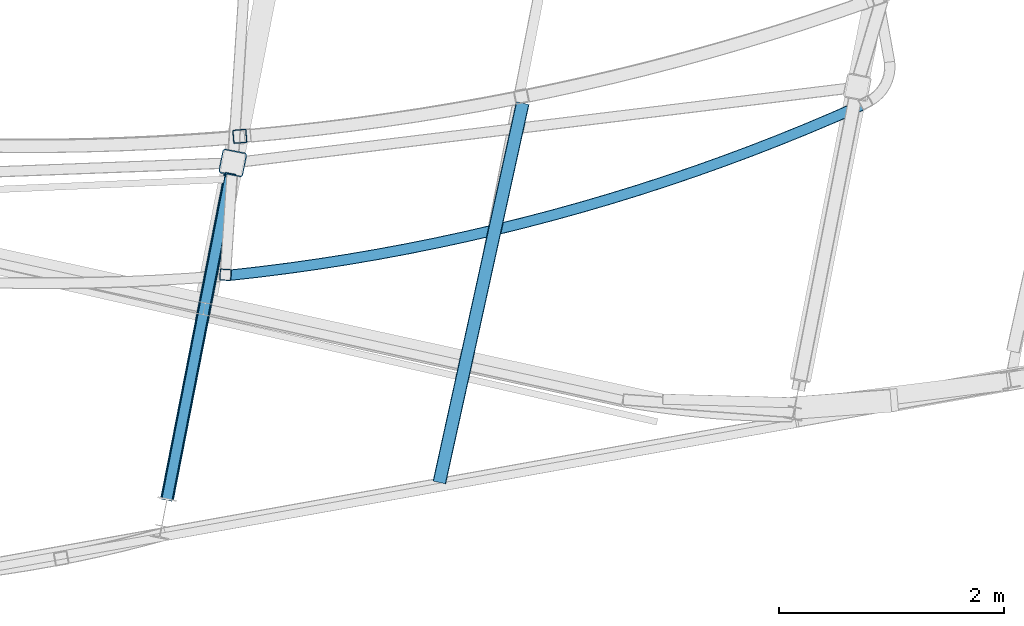
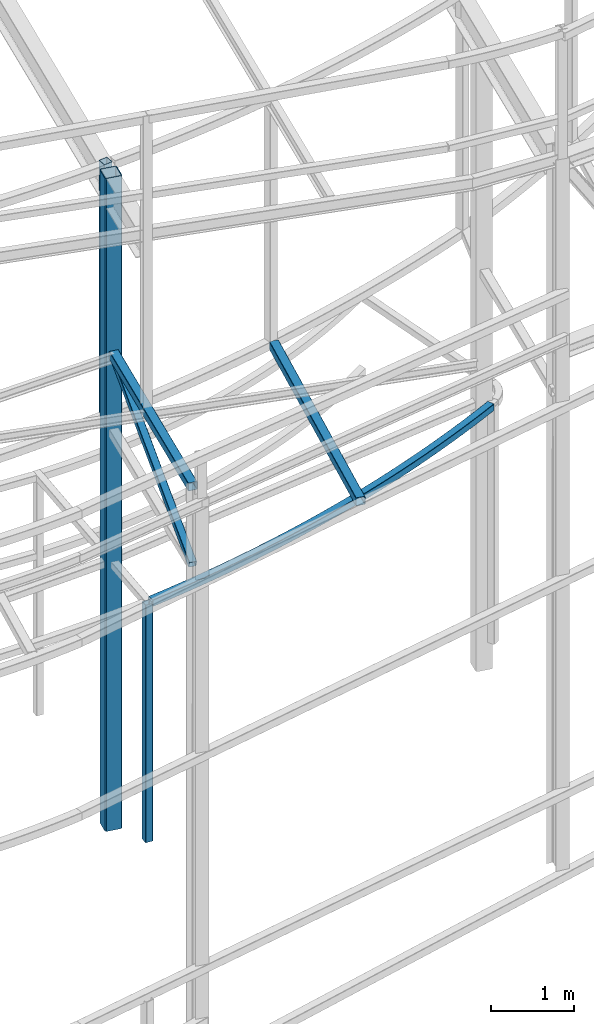
# One storey, part 52 of 215: 6 beams, 1 member, 7 elements without a shape of their own.
"""IFC2X3 building model written with IfcOpenShell, lengths in millimetres."""

from ifc_helpers import new_model, entity, si_unit, frame, origin_with_axes, origin_2d_with_axis, place, context, subcontext, project, spatial, hollow_rectangle, extrude, material, type_object, element, aggregate, save


model = new_model("IFC2X3")

# Units and contexts
model_context = context("Model", 3, precision=1e-05, world=origin_with_axes())
body_context = subcontext(model_context, "Body", "Model", "MODEL_VIEW")
ifc_project = project(units=[si_unit("LENGTHUNIT", "METRE", prefix="MILLI"), si_unit("AREAUNIT", "SQUARE_METRE"), si_unit("VOLUMEUNIT", "CUBIC_METRE"), si_unit("MASSUNIT", "GRAM", prefix="KILO"), si_unit("TIMEUNIT", "SECOND"), si_unit("PLANEANGLEUNIT", "RADIAN"), si_unit("SOLIDANGLEUNIT", "STERADIAN"), si_unit("THERMODYNAMICTEMPERATUREUNIT", "DEGREE_CELSIUS"), si_unit("LUMINOUSINTENSITYUNIT", "LUMEN")], contexts=[model_context])

# Site, building, storey
site_placement = place(None, origin_with_axes())
site = spatial("IfcSite", under=ifc_project, at=site_placement, CompositionType="ELEMENT")
building_placement = place(site_placement, origin_with_axes())
building = spatial("IfcBuilding", under=site, at=building_placement, Name="Undefined", CompositionType="ELEMENT")
storey_placement = place(building_placement, origin_with_axes())
storey = spatial("IfcBuildingStorey", under=building, at=storey_placement, Name="Undefined", CompositionType="ELEMENT", Elevation=0.0)

# Assembly, beam
assembly_1_placement = place(storey_placement, origin_with_axes())
assembly_1 = element("IfcElementAssembly", 1, at=assembly_1_placement, inside=storey, Name="Steel Assembly", AssemblyPlace="NOTDEFINED", PredefinedType="RIGID_FRAME")
ifc_material = material(Name="STEEL/S275JR")
beam_type_1 = type_object("IfcBeamType", PredefinedType="NOTDEFINED")
beam_1_placement = place(assembly_1_placement, frame((79141.1914420847, 2960.93035332073, 6760.00000147689), z_axis=(-0.259963625925388, 0.96561840972287, 0.0), x_axis=(0.96561840972287, 0.259963625925391, 0.0)))
beam_1 = element("IfcBeam", 2, at=beam_1_placement, type_object=beam_type_1, material=ifc_material, Name="POUTRE", context=body_context, shape_type="SweptSolid", body=[
    entity("IfcRevolvedAreaSolid", entity("IfcRectangleHollowProfileDef", "AREA", None, entity("IfcAxis2Placement2D", entity("IfcCartesianPoint", [0.0, 0.0]), entity("IfcDirection", [1.0, 0.0])), 100.0, 100.0, 4.0, 4.0, 8.0), entity("IfcAxis2Placement3D", entity("IfcCartesianPoint", [5816.07348706532, 0.0, -3.22856934912592e-13]), entity("IfcDirection", [-0.987500292888729, 0.0, -0.157617167671147]), entity("IfcDirection", [-6.93889390390723e-18, -1.0, -3.46944695195361e-18])), entity("IfcAxis1Placement", entity("IfcCartesianPoint", [0.0, 18450.0, 0.0]), entity("IfcDirection", [-1.0, 0.0, 0.0])), 0.316554383414073),
])
aggregate(assembly_1, [beam_1])

assembly_2_placement = place(storey_placement, origin_with_axes())
assembly_2 = element("IfcElementAssembly", 3, at=assembly_2_placement, inside=storey, Name="Steel Assembly", AssemblyPlace="NOTDEFINED", PredefinedType="RIGID_FRAME")
beam_2_placement = place(assembly_2_placement, frame((79099.7624666083, 2964.33186140651, 6760.00000147429), z_axis=(-0.99789749179923, 0.0648120039869599, 0.0), x_axis=(0.0, 0.0, -1.0)))
beam_2 = element("IfcBeam", 4, at=beam_2_placement, type_object=beam_type_1, material=ifc_material, Name="MONTANT", context=body_context, shape_type="SweptSolid", body=[
    extrude(hollow_rectangle(XDim=100.0, YDim=100.0, WallThickness=4.0, InnerFilletRadius=4.0, OuterFilletRadius=8.0, at=origin_2d_with_axis()), frame((3499.99999998675, 0.0, 0.0), z_axis=(-1.0, 0.0, 0.0), x_axis=(-6.93889390390723e-18, -1.0, -3.46944695195361e-18)), (0.0, 0.0, 1.0), 3500.0),
])
aggregate(assembly_2, [beam_2])

assembly_3_placement = place(storey_placement, origin_with_axes())
assembly_3 = element("IfcElementAssembly", 5, at=assembly_3_placement, inside=storey, Name="Steel Assembly", AssemblyPlace="NOTDEFINED", PredefinedType="RIGID_FRAME")
beam_type_2 = type_object("IfcBeamType", PredefinedType="NOTDEFINED")
beam_3_placement = place(assembly_3_placement, frame((81745.0894080744, 4492.63761610524, 8706.00014747974), z_axis=(0.976698644234717, -0.214615373051574, -1.00000033877607e-09), x_axis=(-0.214615373051576, -0.976698644234716, 0.0)))
beam_3 = element("IfcBeam", 6, at=beam_3_placement, type_object=beam_type_2, material=ifc_material, Name="LISSE", context=body_context, shape_type="SweptSolid", body=[
    extrude(hollow_rectangle(XDim=120.0, YDim=120.0, WallThickness=5.0, InnerFilletRadius=5.0, OuterFilletRadius=10.0, at=origin_2d_with_axis()), frame((3456.86944532701, -1.8189894034565e-12, -1.44559678270837e-11), z_axis=(-1.0, 0.0, 0.0), x_axis=(-6.93889390390723e-18, -1.0, -3.46944695195361e-18)), (0.0, 0.0, 1.0), 3456.9),
])
aggregate(assembly_3, [beam_3])

assembly_4_placement = place(storey_placement, origin_with_axes())
assembly_4 = element("IfcElementAssembly", 7, at=assembly_4_placement, inside=storey, Name="Steel Assembly", AssemblyPlace="NOTDEFINED", PredefinedType="RIGID_FRAME")
beam_4_placement = place(assembly_4_placement, frame((79227.4232070011, 4197.03980497045, 12475.1396951429), z_axis=(0.084389618980237, -0.996432833766717, 0.0), x_axis=(0.0, 0.0, -1.0)))
beam_4 = element("IfcBeam", 8, at=beam_4_placement, type_object=beam_type_2, material=ifc_material, Name="LISSE", context=body_context, shape_type="SweptSolid", body=[
    extrude(hollow_rectangle(XDim=120.0, YDim=120.0, WallThickness=5.0, InnerFilletRadius=5.0, OuterFilletRadius=10.0, at=origin_2d_with_axis()), frame((3709.13889381245, -1.45519152283669e-11, 4.54747351653496e-13), z_axis=(-1.0, 0.0, 0.0), x_axis=(-6.93889390390723e-18, -1.0, -3.46944695195361e-18)), (0.0, 0.0, 1.0), 3709.1),
])
aggregate(assembly_4, [beam_4])

assembly_5_placement = place(storey_placement, origin_with_axes())
assembly_5 = element("IfcElementAssembly", 9, at=assembly_5_placement, inside=storey, Name="Steel Assembly", AssemblyPlace="NOTDEFINED", PredefinedType="RIGID_FRAME")
beam_5_placement = place(assembly_5_placement, frame((78580.6901033137, 974.47808886056, 9859.9838858968), z_axis=(-0.981422412140383, 0.191859451027444, 0.0), x_axis=(0.191859470081235, 0.981422408415534, 0.0)))
beam_5 = element("IfcBeam", 10, at=beam_5_placement, type_object=beam_type_2, material=ifc_material, context=body_context, shape_type="SweptSolid", body=[
    extrude(hollow_rectangle(XDim=120.0, YDim=120.0, WallThickness=5.0, InnerFilletRadius=5.0, OuterFilletRadius=10.0, at=origin_2d_with_axis()), frame((2932.26845998588, 5.62583432590047e-16, -6.06378905225262e-22), z_axis=(-1.0, 0.0, 0.0), x_axis=(-6.93889390390723e-18, -1.0, -3.46944695195361e-18)), (0.0, 0.0, 1.0), 2932.3),
])
aggregate(assembly_5, [beam_5])

# Assembly, member
assembly_6_placement = place(storey_placement, origin_with_axes())
assembly_6 = element("IfcElementAssembly", 11, at=assembly_6_placement, inside=storey, Name="Steel Assembly", AssemblyPlace="NOTDEFINED", PredefinedType="RIGID_FRAME")
member_type = type_object("IfcMemberType", PredefinedType="NOTDEFINED")
member_placement = place(assembly_6_placement, frame((79143.273498129, 3852.27207940734, 9859.98388262023), z_axis=(-0.981398902628277, 0.191979417927285, -0.000311467999881905), x_axis=(-0.178614549027423, -0.91367003814027, -0.365108072056053)))
member = element("IfcMember", 12, at=member_placement, type_object=member_type, material=ifc_material, context=body_context, shape_type="SweptSolid", body=[
    extrude(hollow_rectangle(XDim=100.0, YDim=100.0, WallThickness=5.0, InnerFilletRadius=5.0, OuterFilletRadius=10.0, at=origin_2d_with_axis()), frame((3149.70811345631, -4.54747350886464e-13, 1.51494405326898e-13), z_axis=(-1.0, 0.0, 0.0), x_axis=(-6.93889390390723e-18, -1.0, -3.46944695195361e-18)), (0.0, 0.0, 1.0), 3149.7),
])
aggregate(assembly_6, [member])

# Assembly, beam
assembly_7_placement = place(storey_placement, origin_with_axes())
assembly_7 = element("IfcElementAssembly", 13, at=assembly_7_placement, inside=storey, Name="Steel Assembly", AssemblyPlace="NOTDEFINED", PredefinedType="RIGID_FRAME")
beam_type_3 = type_object("IfcBeamType", PredefinedType="NOTDEFINED")
beam_6_placement = place(assembly_7_placement, frame((79164.3780381256, 3960.22854622053, 12473.49065201), z_axis=(0.191859470081235, 0.981422408415534, 0.0), x_axis=(0.0, 0.0, -1.0)))
beam_6 = element("IfcBeam", 14, at=beam_6_placement, type_object=beam_type_3, material=ifc_material, Name="POTEAU", context=body_context, shape_type="SweptSolid", body=[
    extrude(hollow_rectangle(XDim=220.0, YDim=220.0, WallThickness=10.0, InnerFilletRadius=15.0, OuterFilletRadius=25.0, at=origin_2d_with_axis()), frame((9623.49274719088, 0.0, 0.0), z_axis=(-1.0, 0.0, 0.0), x_axis=(-6.93889390390723e-18, -1.0, -3.46944695195361e-18)), (0.0, 0.0, 1.0), 9623.5),
])
aggregate(assembly_7, [beam_6])

save(model, "model.ifc")
